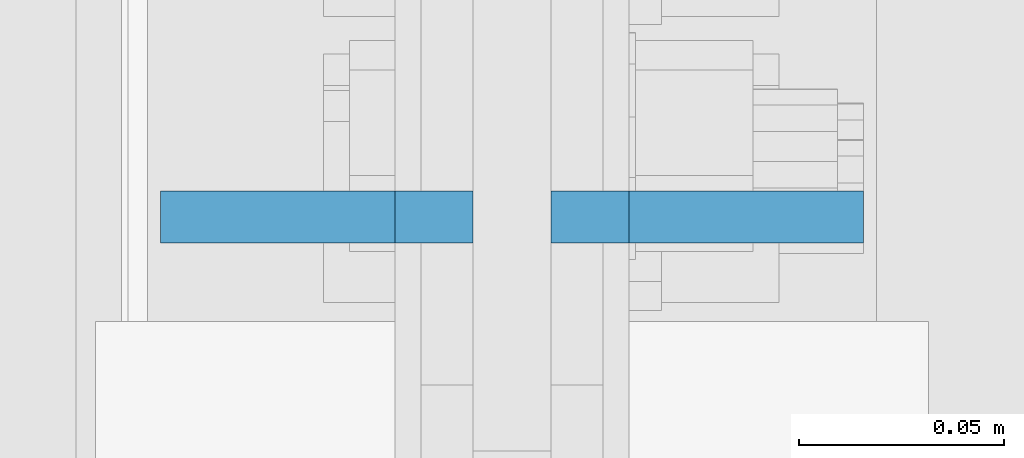
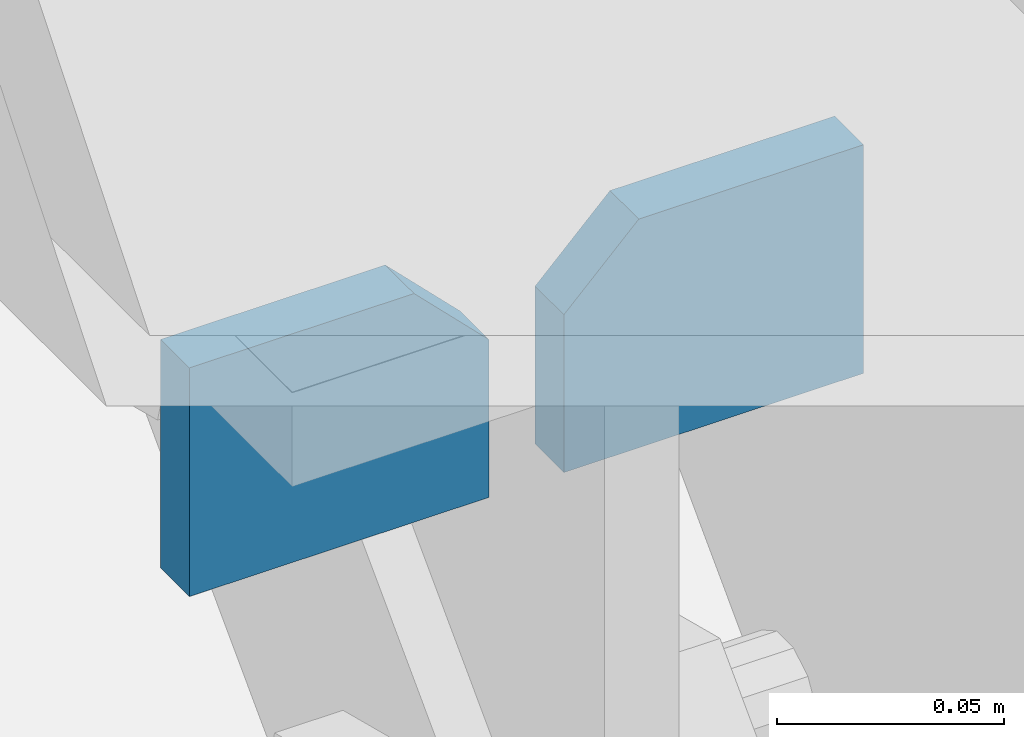
# One storey, part 1120 of 1179: 2 plates, 1 element without a shape of its own.
"""IFC2X3 building model written with IfcOpenShell, lengths in millimetres."""

from ifc_helpers import new_model, si_unit, frame, origin_with_axes, place, context, subcontext, project, spatial, faceted_brep, material, type_object, element, aggregate, save


model = new_model("IFC2X3")

# Units and contexts
model_context = context("Model", 3, precision=1e-05, world=origin_with_axes())
body_context = subcontext(model_context, "Body", "Model", "MODEL_VIEW")
ifc_project = project(units=[si_unit("LENGTHUNIT", "METRE", prefix="MILLI"), si_unit("AREAUNIT", "SQUARE_METRE"), si_unit("VOLUMEUNIT", "CUBIC_METRE"), si_unit("MASSUNIT", "GRAM", prefix="KILO"), si_unit("TIMEUNIT", "SECOND"), si_unit("PLANEANGLEUNIT", "RADIAN"), si_unit("SOLIDANGLEUNIT", "STERADIAN"), si_unit("THERMODYNAMICTEMPERATUREUNIT", "DEGREE_CELSIUS"), si_unit("LUMINOUSINTENSITYUNIT", "LUMEN")], contexts=[model_context])

# Site, building, storey
site_placement = place(None, origin_with_axes())
site = spatial("IfcSite", under=ifc_project, at=site_placement, CompositionType="ELEMENT")
building_placement = place(site_placement, origin_with_axes())
building = spatial("IfcBuilding", under=site, at=building_placement, Name="Undefined", CompositionType="ELEMENT")
storey_placement = place(building_placement, origin_with_axes())
storey = spatial("IfcBuildingStorey", under=building, at=storey_placement, Name="Undefined", CompositionType="ELEMENT", Elevation=0.0)

# Assembly, plates
assembly_placement = place(storey_placement, origin_with_axes())
assembly = element("IfcElementAssembly", 1, at=assembly_placement, inside=storey, Name="BEAM", AssemblyPlace="NOTDEFINED", PredefinedType="RIGID_FRAME")
ifc_material = material(Name="STEEL/A572-GR.50")
plate_type = type_object("IfcPlateType", PredefinedType="NOTDEFINED")
plate_1_placement = place(assembly_placement, frame((24298.275, 14935.2, 7683.499999623), z_axis=(-1.0, 0.0, 0.0), x_axis=(0.0, 0.0, -1.0)))
plate_1 = element("IfcPlate", 2, at=plate_1_placement, type_object=plate_type, material=ifc_material, Name="PLATE", context=body_context, shape_type="Brep", body=[
    faceted_brep([(0.0, 6.35000000000036, 19.0499999999993), (19.0500000000002, 6.35000000000036, 0.0), (19.0500000000002, -6.35000000000036, 0.0), (0.0, -6.35000000000036, 19.0499999999993), (0.0, -6.35000000000036, 76.2000000000044), (0.0, 6.35000000000036, 76.2000000000044), (61.493348936805, -6.35000000000036, 76.2000000000044), (61.493348936805, 6.35000000000036, 76.2000000000044), (61.493348936805, -6.35000000000036, 0.0), (61.493348936805, 6.35000000000036, 0.0)], [[[0, 1, 2, 3]], [[4, 5, 0, 3]], [[4, 6, 7, 5]], [[6, 8, 9, 7]], [[9, 8, 2, 1]], [[5, 7, 9, 1, 0]], [[8, 6, 4, 3, 2]]]),
])
plate_2_placement = place(assembly_placement, frame((24317.325, 14935.2, 7683.499999623), z_axis=(1.0, 0.0, 0.0), x_axis=(0.0, 0.0, -1.0)))
plate_2 = element("IfcPlate", 3, at=plate_2_placement, type_object=plate_type, material=ifc_material, Name="PLATE", context=body_context, shape_type="Brep", body=[
    faceted_brep([(0.0, 6.35000000000036, 19.0499999999993), (19.0500000000002, 6.35000000000036, 0.0), (19.0500000000002, -6.35000000000036, 0.0), (0.0, -6.35000000000036, 19.0499999999993), (0.0, -6.35000000000036, 76.2000000000044), (0.0, 6.35000000000036, 76.2000000000044), (61.493348936805, -6.35000000000036, 76.2000000000044), (61.493348936805, 6.35000000000036, 76.2000000000044), (61.493348936805, -6.35000000000036, 0.0), (61.493348936805, 6.35000000000036, 0.0)], [[[0, 1, 2, 3]], [[4, 5, 0, 3]], [[4, 6, 7, 5]], [[6, 8, 9, 7]], [[9, 8, 2, 1]], [[5, 7, 9, 1, 0]], [[8, 6, 4, 3, 2]]]),
])
aggregate(assembly, [plate_1, plate_2])

save(model, "model.ifc")
